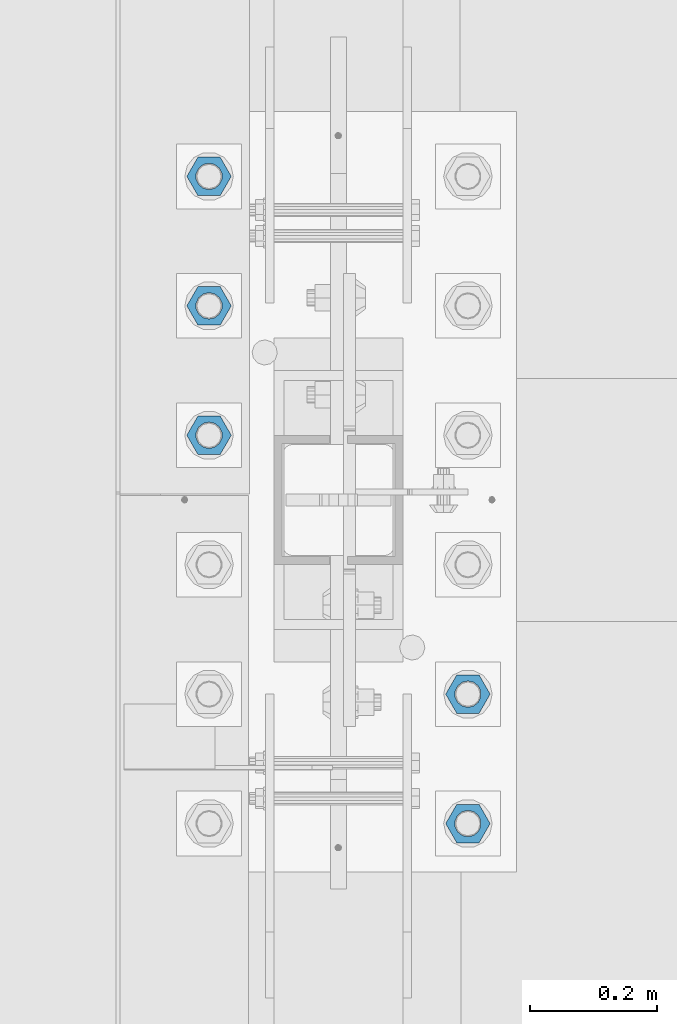
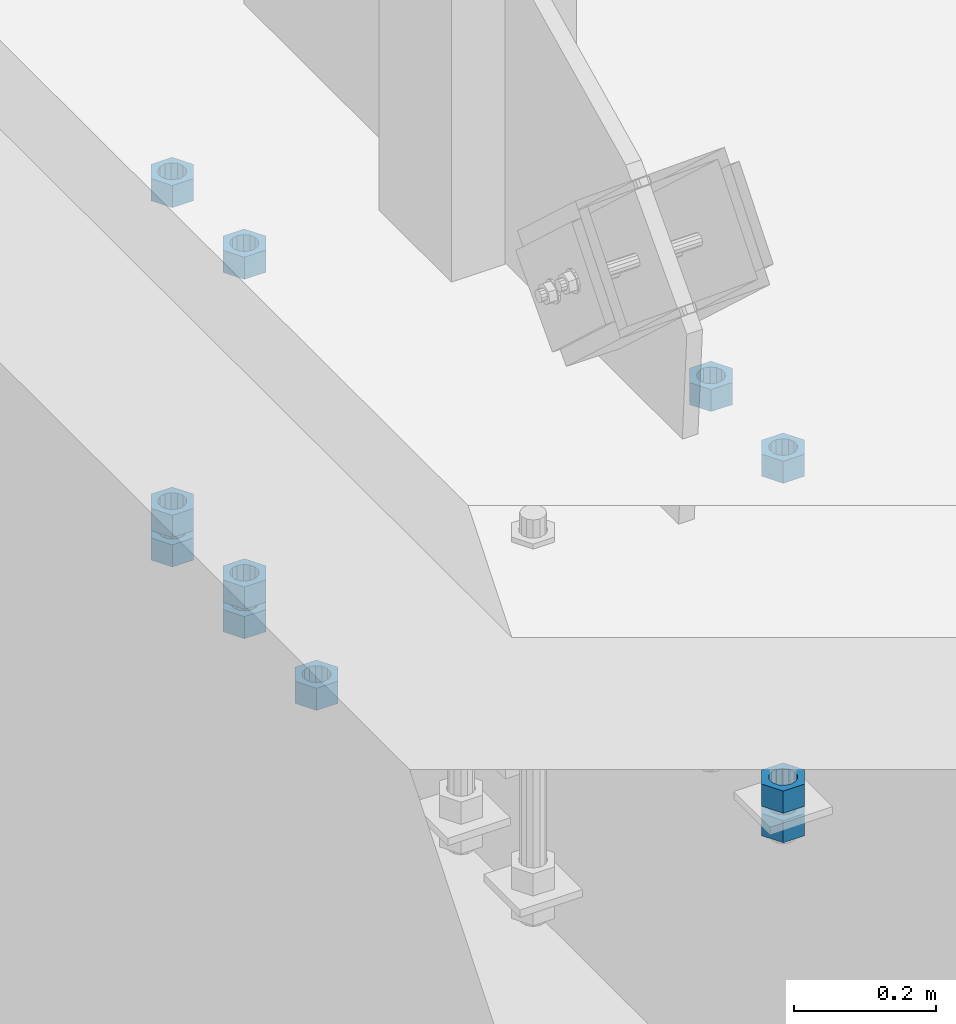
# One storey, part 985 of 1763: 11 columns, 1 element without a shape of its own.
"""IFC2X3 building model written with IfcOpenShell, lengths in millimetres."""

from ifc_helpers import new_model, si_unit, frame, origin_with_axes, place, context, subcontext, project, spatial, faceted_brep, material, type_object, element, aggregate, save


model = new_model("IFC2X3")

# Units and contexts
model_context = context("Model", 3, precision=1e-05, world=origin_with_axes())
body_context = subcontext(model_context, "Body", "Model", "MODEL_VIEW")
ifc_project = project(units=[si_unit("LENGTHUNIT", "METRE", prefix="MILLI"), si_unit("AREAUNIT", "SQUARE_METRE"), si_unit("VOLUMEUNIT", "CUBIC_METRE"), si_unit("MASSUNIT", "GRAM", prefix="KILO"), si_unit("TIMEUNIT", "SECOND"), si_unit("PLANEANGLEUNIT", "RADIAN"), si_unit("SOLIDANGLEUNIT", "STERADIAN"), si_unit("THERMODYNAMICTEMPERATUREUNIT", "DEGREE_CELSIUS"), si_unit("LUMINOUSINTENSITYUNIT", "LUMEN")], contexts=[model_context])

# Site, building, storey
site_placement = place(None, origin_with_axes())
site = spatial("IfcSite", under=ifc_project, at=site_placement, CompositionType="ELEMENT")
building_placement = place(site_placement, origin_with_axes())
building = spatial("IfcBuilding", under=site, at=building_placement, Name="Undefined", CompositionType="ELEMENT")
storey_placement = place(building_placement, origin_with_axes())
storey = spatial("IfcBuildingStorey", under=building, at=storey_placement, Name="Undefined", CompositionType="ELEMENT", Elevation=0.0)

# Assembly, columns
assembly_placement = place(storey_placement, origin_with_axes())
assembly = element("IfcElementAssembly", 1, at=assembly_placement, inside=storey, Name="TEMPLATE", AssemblyPlace="NOTDEFINED", PredefinedType="RIGID_FRAME")
ifc_material = material(Name="STEEL/A563")
column_type = type_object("IfcColumnType", Name="1-1/2_HEAVY_HEX_NUT", PredefinedType="NOTDEFINED")
column_1_placement = place(assembly_placement, frame((-87172.2372736984, -50.7999999999992, 5189.5375), z_axis=(0.0, 1.0, 0.0), x_axis=(0.0, 0.0, -1.0)))
column_1 = element("IfcColumn", 2, at=column_1_placement, type_object=column_type, material=ifc_material, Name="NUT", ObjectType="1-1/2_HEAVY_HEX_NUT", context=body_context, shape_type="Brep", body=[
    faceted_brep([(0.0, -34.9199981689453, 0.0), (0.0, -17.4599990844727, -30.25), (38.1000000000004, -17.4599990844727, -30.25), (38.1000000000004, -34.9199981689453, 0.0), (0.0, 17.4599990844727, -30.25), (38.1000000000004, 17.4599990844727, -30.25), (0.0, 34.9199981689453, 0.0), (38.1000000000004, 34.9199981689453, 0.0), (0.0, 17.4599990844727, 30.25), (38.1000000000004, 17.4599990844727, 30.25), (0.0, -17.4599990844727, 30.25), (38.1000000000004, -17.4599990844727, 30.25), (0.0, 0.0, 20.6399993896484), (0.0, 8.95536011056538, 18.5959968835978), (38.1000000000004, 8.95536011056538, 18.5959968835978), (38.1000000000004, 0.0, 20.6399993896484), (0.0, 16.1370013209453, 12.8688291298167), (38.1000000000004, 16.1370013209453, 12.8688291298167), (0.0, 20.1225115123816, 4.59283194104137), (38.1000000000004, 20.1225115123816, 4.59283194104137), (0.0, 20.1225115123816, -4.59283194104319), (38.1000000000004, 20.1225115123816, -4.59283194104319), (0.0, 16.1370013209453, -12.8688291298167), (38.1000000000004, 16.1370013209453, -12.8688291298167), (0.0, 8.95536011056538, -18.5959968835978), (38.1000000000004, 8.95536011056538, -18.5959968835978), (0.0, 0.0, -20.6399993896484), (38.1000000000004, 0.0, -20.6399993896484), (0.0, -8.95536011056538, -18.5959968835978), (38.1000000000004, -8.95536011056538, -18.5959968835978), (0.0, -16.1370013209453, -12.8688291298167), (38.1000000000004, -16.1370013209453, -12.8688291298167), (0.0, -20.1225115123816, -4.59283194104137), (38.1000000000004, -20.1225115123816, -4.59283194104137), (0.0, -20.1225115123816, 4.59283194104319), (38.1000000000004, -20.1225115123816, 4.59283194104319), (0.0, -16.1370013209453, 12.8688291298167), (38.1000000000004, -16.1370013209453, 12.8688291298167), (0.0, -8.95536011056538, 18.5959968835978), (38.1000000000004, -8.95536011056538, 18.5959968835978)], [[[0, 1, 2, 3]], [[1, 4, 5, 2]], [[4, 6, 7, 5]], [[6, 8, 9, 7]], [[8, 10, 11, 9]], [[10, 0, 3, 11]], [[12, 13, 14, 15]], [[13, 16, 17, 14]], [[16, 18, 19, 17]], [[18, 20, 21, 19]], [[20, 22, 23, 21]], [[22, 24, 25, 23]], [[24, 26, 27, 25]], [[26, 28, 29, 27]], [[28, 30, 31, 29]], [[30, 32, 33, 31]], [[32, 34, 35, 33]], [[34, 36, 37, 35]], [[36, 38, 39, 37]], [[38, 12, 15, 39]], [[5, 7, 9, 11, 3, 2], [17, 19, 21, 23, 25, 27, 29, 31, 33, 35, 37, 39, 15, 14]], [[10, 8, 6, 4, 1, 0], [38, 36, 34, 32, 30, 28, 26, 24, 22, 20, 18, 16, 13, 12]]]),
])
column_2_placement = place(assembly_placement, frame((-87172.2372736984, -50.7999999999992, 4622.8), z_axis=(0.0, 1.0, 0.0), x_axis=(0.0, 0.0, -1.0)))
column_2 = element("IfcColumn", 3, at=column_2_placement, type_object=column_type, material=ifc_material, Name="NUT", ObjectType="1-1/2_HEAVY_HEX_NUT", context=body_context, shape_type="Brep", body=[
    faceted_brep([(0.0, -34.9199981689453, 0.0), (0.0, -17.4599990844727, -30.25), (38.1000000000004, -17.4599990844727, -30.25), (38.1000000000004, -34.9199981689453, 0.0), (0.0, 17.4599990844727, -30.25), (38.1000000000004, 17.4599990844727, -30.25), (0.0, 34.9199981689453, 0.0), (38.1000000000004, 34.9199981689453, 0.0), (0.0, 17.4599990844727, 30.25), (38.1000000000004, 17.4599990844727, 30.25), (0.0, -17.4599990844727, 30.25), (38.1000000000004, -17.4599990844727, 30.25), (0.0, 0.0, 20.6399993896484), (0.0, 8.95536011056538, 18.5959968835978), (38.1000000000004, 8.95536011056538, 18.5959968835978), (38.1000000000004, 0.0, 20.6399993896484), (0.0, 16.1370013209453, 12.8688291298167), (38.1000000000004, 16.1370013209453, 12.8688291298167), (0.0, 20.1225115123816, 4.59283194104137), (38.1000000000004, 20.1225115123816, 4.59283194104137), (0.0, 20.1225115123816, -4.59283194104319), (38.1000000000004, 20.1225115123816, -4.59283194104319), (0.0, 16.1370013209453, -12.8688291298167), (38.1000000000004, 16.1370013209453, -12.8688291298167), (0.0, 8.95536011056538, -18.5959968835978), (38.1000000000004, 8.95536011056538, -18.5959968835978), (0.0, 0.0, -20.6399993896484), (38.1000000000004, 0.0, -20.6399993896484), (0.0, -8.95536011056538, -18.5959968835978), (38.1000000000004, -8.95536011056538, -18.5959968835978), (0.0, -16.1370013209453, -12.8688291298167), (38.1000000000004, -16.1370013209453, -12.8688291298167), (0.0, -20.1225115123816, -4.59283194104137), (38.1000000000004, -20.1225115123816, -4.59283194104137), (0.0, -20.1225115123816, 4.59283194104319), (38.1000000000004, -20.1225115123816, 4.59283194104319), (0.0, -16.1370013209453, 12.8688291298167), (38.1000000000004, -16.1370013209453, 12.8688291298167), (0.0, -8.95536011056538, 18.5959968835978), (38.1000000000004, -8.95536011056538, 18.5959968835978)], [[[0, 1, 2, 3]], [[1, 4, 5, 2]], [[4, 6, 7, 5]], [[6, 8, 9, 7]], [[8, 10, 11, 9]], [[10, 0, 3, 11]], [[12, 13, 14, 15]], [[13, 16, 17, 14]], [[16, 18, 19, 17]], [[18, 20, 21, 19]], [[20, 22, 23, 21]], [[22, 24, 25, 23]], [[24, 26, 27, 25]], [[26, 28, 29, 27]], [[28, 30, 31, 29]], [[30, 32, 33, 31]], [[32, 34, 35, 33]], [[34, 36, 37, 35]], [[36, 38, 39, 37]], [[38, 12, 15, 39]], [[5, 7, 9, 11, 3, 2], [17, 19, 21, 23, 25, 27, 29, 31, 33, 35, 37, 39, 15, 14]], [[10, 8, 6, 4, 1, 0], [38, 36, 34, 32, 30, 28, 26, 24, 22, 20, 18, 16, 13, 12]]]),
])
column_3_placement = place(assembly_placement, frame((-87172.2372736984, -50.7999999999992, 4572.0), z_axis=(0.0, 1.0, 0.0), x_axis=(0.0, 0.0, -1.0)))
column_3 = element("IfcColumn", 4, at=column_3_placement, type_object=column_type, material=ifc_material, Name="NUT", ObjectType="1-1/2_HEAVY_HEX_NUT", context=body_context, shape_type="Brep", body=[
    faceted_brep([(0.0, -34.9199981689453, 0.0), (0.0, -17.4599990844727, -30.25), (38.1000000000004, -17.4599990844727, -30.25), (38.1000000000004, -34.9199981689453, 0.0), (0.0, 17.4599990844727, -30.25), (38.1000000000004, 17.4599990844727, -30.25), (0.0, 34.9199981689453, 0.0), (38.1000000000004, 34.9199981689453, 0.0), (0.0, 17.4599990844727, 30.25), (38.1000000000004, 17.4599990844727, 30.25), (0.0, -17.4599990844727, 30.25), (38.1000000000004, -17.4599990844727, 30.25), (0.0, 0.0, 20.6399993896484), (0.0, 8.95536011056538, 18.5959968835978), (38.1000000000004, 8.95536011056538, 18.5959968835978), (38.1000000000004, 0.0, 20.6399993896484), (0.0, 16.1370013209453, 12.8688291298167), (38.1000000000004, 16.1370013209453, 12.8688291298167), (0.0, 20.1225115123816, 4.59283194104137), (38.1000000000004, 20.1225115123816, 4.59283194104137), (0.0, 20.1225115123816, -4.59283194104319), (38.1000000000004, 20.1225115123816, -4.59283194104319), (0.0, 16.1370013209453, -12.8688291298167), (38.1000000000004, 16.1370013209453, -12.8688291298167), (0.0, 8.95536011056538, -18.5959968835978), (38.1000000000004, 8.95536011056538, -18.5959968835978), (0.0, 0.0, -20.6399993896484), (38.1000000000004, 0.0, -20.6399993896484), (0.0, -8.95536011056538, -18.5959968835978), (38.1000000000004, -8.95536011056538, -18.5959968835978), (0.0, -16.1370013209453, -12.8688291298167), (38.1000000000004, -16.1370013209453, -12.8688291298167), (0.0, -20.1225115123816, -4.59283194104137), (38.1000000000004, -20.1225115123816, -4.59283194104137), (0.0, -20.1225115123816, 4.59283194104319), (38.1000000000004, -20.1225115123816, 4.59283194104319), (0.0, -16.1370013209453, 12.8688291298167), (38.1000000000004, -16.1370013209453, 12.8688291298167), (0.0, -8.95536011056538, 18.5959968835978), (38.1000000000004, -8.95536011056538, 18.5959968835978)], [[[0, 1, 2, 3]], [[1, 4, 5, 2]], [[4, 6, 7, 5]], [[6, 8, 9, 7]], [[8, 10, 11, 9]], [[10, 0, 3, 11]], [[12, 13, 14, 15]], [[13, 16, 17, 14]], [[16, 18, 19, 17]], [[18, 20, 21, 19]], [[20, 22, 23, 21]], [[22, 24, 25, 23]], [[24, 26, 27, 25]], [[26, 28, 29, 27]], [[28, 30, 31, 29]], [[30, 32, 33, 31]], [[32, 34, 35, 33]], [[34, 36, 37, 35]], [[36, 38, 39, 37]], [[38, 12, 15, 39]], [[5, 7, 9, 11, 3, 2], [17, 19, 21, 23, 25, 27, 29, 31, 33, 35, 37, 39, 15, 14]], [[10, 8, 6, 4, 1, 0], [38, 36, 34, 32, 30, 28, 26, 24, 22, 20, 18, 16, 13, 12]]]),
])
column_4_placement = place(assembly_placement, frame((-87172.2372736984, 152.400000000001, 5189.5375), z_axis=(0.0, 1.0, 0.0), x_axis=(0.0, 0.0, -1.0)))
column_4 = element("IfcColumn", 5, at=column_4_placement, type_object=column_type, material=ifc_material, Name="NUT", ObjectType="1-1/2_HEAVY_HEX_NUT", context=body_context, shape_type="Brep", body=[
    faceted_brep([(0.0, -34.9199981689453, 0.0), (0.0, -17.4599990844727, -30.25), (38.1000000000004, -17.4599990844727, -30.25), (38.1000000000004, -34.9199981689453, 0.0), (0.0, 17.4599990844727, -30.25), (38.1000000000004, 17.4599990844727, -30.25), (0.0, 34.9199981689453, 0.0), (38.1000000000004, 34.9199981689453, 0.0), (0.0, 17.4599990844727, 30.25), (38.1000000000004, 17.4599990844727, 30.25), (0.0, -17.4599990844727, 30.25), (38.1000000000004, -17.4599990844727, 30.25), (0.0, 0.0, 20.6399993896484), (0.0, 8.95536011056538, 18.5959968835978), (38.1000000000004, 8.95536011056538, 18.5959968835978), (38.1000000000004, 0.0, 20.6399993896484), (0.0, 16.1370013209453, 12.8688291298167), (38.1000000000004, 16.1370013209453, 12.8688291298167), (0.0, 20.1225115123816, 4.59283194104137), (38.1000000000004, 20.1225115123816, 4.59283194104137), (0.0, 20.1225115123816, -4.59283194104319), (38.1000000000004, 20.1225115123816, -4.59283194104319), (0.0, 16.1370013209453, -12.8688291298167), (38.1000000000004, 16.1370013209453, -12.8688291298167), (0.0, 8.95536011056538, -18.5959968835978), (38.1000000000004, 8.95536011056538, -18.5959968835978), (0.0, 0.0, -20.6399993896484), (38.1000000000004, 0.0, -20.6399993896484), (0.0, -8.95536011056538, -18.5959968835978), (38.1000000000004, -8.95536011056538, -18.5959968835978), (0.0, -16.1370013209453, -12.8688291298167), (38.1000000000004, -16.1370013209453, -12.8688291298167), (0.0, -20.1225115123816, -4.59283194104137), (38.1000000000004, -20.1225115123816, -4.59283194104137), (0.0, -20.1225115123816, 4.59283194104319), (38.1000000000004, -20.1225115123816, 4.59283194104319), (0.0, -16.1370013209453, 12.8688291298167), (38.1000000000004, -16.1370013209453, 12.8688291298167), (0.0, -8.95536011056538, 18.5959968835978), (38.1000000000004, -8.95536011056538, 18.5959968835978)], [[[0, 1, 2, 3]], [[1, 4, 5, 2]], [[4, 6, 7, 5]], [[6, 8, 9, 7]], [[8, 10, 11, 9]], [[10, 0, 3, 11]], [[12, 13, 14, 15]], [[13, 16, 17, 14]], [[16, 18, 19, 17]], [[18, 20, 21, 19]], [[20, 22, 23, 21]], [[22, 24, 25, 23]], [[24, 26, 27, 25]], [[26, 28, 29, 27]], [[28, 30, 31, 29]], [[30, 32, 33, 31]], [[32, 34, 35, 33]], [[34, 36, 37, 35]], [[36, 38, 39, 37]], [[38, 12, 15, 39]], [[5, 7, 9, 11, 3, 2], [17, 19, 21, 23, 25, 27, 29, 31, 33, 35, 37, 39, 15, 14]], [[10, 8, 6, 4, 1, 0], [38, 36, 34, 32, 30, 28, 26, 24, 22, 20, 18, 16, 13, 12]]]),
])
column_5_placement = place(assembly_placement, frame((-87578.6372736983, 558.800000000001, 4572.0), z_axis=(0.0, -1.0, 0.0), x_axis=(0.0, 0.0, -1.0)))
column_5 = element("IfcColumn", 6, at=column_5_placement, type_object=column_type, material=ifc_material, Name="NUT", ObjectType="1-1/2_HEAVY_HEX_NUT", context=body_context, shape_type="Brep", body=[
    faceted_brep([(0.0, -34.9199981689453, 0.0), (0.0, -17.4599990844727, -30.25), (38.1000000000004, -17.4599990844727, -30.25), (38.1000000000004, -34.9199981689453, 0.0), (0.0, 17.4599990844727, -30.25), (38.1000000000004, 17.4599990844727, -30.25), (0.0, 34.9199981689453, 0.0), (38.1000000000004, 34.9199981689453, 0.0), (0.0, 17.4599990844727, 30.25), (38.1000000000004, 17.4599990844727, 30.25), (0.0, -17.4599990844727, 30.25), (38.1000000000004, -17.4599990844727, 30.25), (0.0, 0.0, 20.6399993896484), (0.0, 8.95536011056538, 18.5959968835978), (38.1000000000004, 8.95536011056538, 18.5959968835978), (38.1000000000004, 0.0, 20.6399993896484), (0.0, 16.1370013209453, 12.8688291298167), (38.1000000000004, 16.1370013209453, 12.8688291298167), (0.0, 20.1225115123816, 4.59283194104137), (38.1000000000004, 20.1225115123816, 4.59283194104137), (0.0, 20.1225115123816, -4.59283194104319), (38.1000000000004, 20.1225115123816, -4.59283194104319), (0.0, 16.1370013209453, -12.8688291298167), (38.1000000000004, 16.1370013209453, -12.8688291298167), (0.0, 8.95536011056538, -18.5959968835978), (38.1000000000004, 8.95536011056538, -18.5959968835978), (0.0, 0.0, -20.6399993896484), (38.1000000000004, 0.0, -20.6399993896484), (0.0, -8.95536011056538, -18.5959968835978), (38.1000000000004, -8.95536011056538, -18.5959968835978), (0.0, -16.1370013209453, -12.8688291298167), (38.1000000000004, -16.1370013209453, -12.8688291298167), (0.0, -20.1225115123816, -4.59283194104137), (38.1000000000004, -20.1225115123816, -4.59283194104137), (0.0, -20.1225115123816, 4.59283194104319), (38.1000000000004, -20.1225115123816, 4.59283194104319), (0.0, -16.1370013209453, 12.8688291298167), (38.1000000000004, -16.1370013209453, 12.8688291298167), (0.0, -8.95536011056538, 18.5959968835978), (38.1000000000004, -8.95536011056538, 18.5959968835978)], [[[0, 1, 2, 3]], [[1, 4, 5, 2]], [[4, 6, 7, 5]], [[6, 8, 9, 7]], [[8, 10, 11, 9]], [[10, 0, 3, 11]], [[12, 13, 14, 15]], [[13, 16, 17, 14]], [[16, 18, 19, 17]], [[18, 20, 21, 19]], [[20, 22, 23, 21]], [[22, 24, 25, 23]], [[24, 26, 27, 25]], [[26, 28, 29, 27]], [[28, 30, 31, 29]], [[30, 32, 33, 31]], [[32, 34, 35, 33]], [[34, 36, 37, 35]], [[36, 38, 39, 37]], [[38, 12, 15, 39]], [[5, 7, 9, 11, 3, 2], [17, 19, 21, 23, 25, 27, 29, 31, 33, 35, 37, 39, 15, 14]], [[10, 8, 6, 4, 1, 0], [38, 36, 34, 32, 30, 28, 26, 24, 22, 20, 18, 16, 13, 12]]]),
])
column_6_placement = place(assembly_placement, frame((-87578.6372736983, 762.000000000001, 5189.5375), z_axis=(0.0, -1.0, 0.0), x_axis=(0.0, 0.0, -1.0)))
column_6 = element("IfcColumn", 7, at=column_6_placement, type_object=column_type, material=ifc_material, Name="NUT", ObjectType="1-1/2_HEAVY_HEX_NUT", context=body_context, shape_type="Brep", body=[
    faceted_brep([(0.0, -34.9199981689453, 0.0), (0.0, -17.4599990844727, -30.25), (38.1000000000004, -17.4599990844727, -30.25), (38.1000000000004, -34.9199981689453, 0.0), (0.0, 17.4599990844727, -30.25), (38.1000000000004, 17.4599990844727, -30.25), (0.0, 34.9199981689453, 0.0), (38.1000000000004, 34.9199981689453, 0.0), (0.0, 17.4599990844727, 30.25), (38.1000000000004, 17.4599990844727, 30.25), (0.0, -17.4599990844727, 30.25), (38.1000000000004, -17.4599990844727, 30.25), (0.0, 0.0, 20.6399993896484), (0.0, 8.95536011056538, 18.5959968835978), (38.1000000000004, 8.95536011056538, 18.5959968835978), (38.1000000000004, 0.0, 20.6399993896484), (0.0, 16.1370013209453, 12.8688291298167), (38.1000000000004, 16.1370013209453, 12.8688291298167), (0.0, 20.1225115123816, 4.59283194104137), (38.1000000000004, 20.1225115123816, 4.59283194104137), (0.0, 20.1225115123816, -4.59283194104319), (38.1000000000004, 20.1225115123816, -4.59283194104319), (0.0, 16.1370013209453, -12.8688291298167), (38.1000000000004, 16.1370013209453, -12.8688291298167), (0.0, 8.95536011056538, -18.5959968835978), (38.1000000000004, 8.95536011056538, -18.5959968835978), (0.0, 0.0, -20.6399993896484), (38.1000000000004, 0.0, -20.6399993896484), (0.0, -8.95536011056538, -18.5959968835978), (38.1000000000004, -8.95536011056538, -18.5959968835978), (0.0, -16.1370013209453, -12.8688291298167), (38.1000000000004, -16.1370013209453, -12.8688291298167), (0.0, -20.1225115123816, -4.59283194104137), (38.1000000000004, -20.1225115123816, -4.59283194104137), (0.0, -20.1225115123816, 4.59283194104319), (38.1000000000004, -20.1225115123816, 4.59283194104319), (0.0, -16.1370013209453, 12.8688291298167), (38.1000000000004, -16.1370013209453, 12.8688291298167), (0.0, -8.95536011056538, 18.5959968835978), (38.1000000000004, -8.95536011056538, 18.5959968835978)], [[[0, 1, 2, 3]], [[1, 4, 5, 2]], [[4, 6, 7, 5]], [[6, 8, 9, 7]], [[8, 10, 11, 9]], [[10, 0, 3, 11]], [[12, 13, 14, 15]], [[13, 16, 17, 14]], [[16, 18, 19, 17]], [[18, 20, 21, 19]], [[20, 22, 23, 21]], [[22, 24, 25, 23]], [[24, 26, 27, 25]], [[26, 28, 29, 27]], [[28, 30, 31, 29]], [[30, 32, 33, 31]], [[32, 34, 35, 33]], [[34, 36, 37, 35]], [[36, 38, 39, 37]], [[38, 12, 15, 39]], [[5, 7, 9, 11, 3, 2], [17, 19, 21, 23, 25, 27, 29, 31, 33, 35, 37, 39, 15, 14]], [[10, 8, 6, 4, 1, 0], [38, 36, 34, 32, 30, 28, 26, 24, 22, 20, 18, 16, 13, 12]]]),
])
column_7_placement = place(assembly_placement, frame((-87578.6372736983, 762.000000000001, 4622.8), z_axis=(0.0, -1.0, 0.0), x_axis=(0.0, 0.0, -1.0)))
column_7 = element("IfcColumn", 8, at=column_7_placement, type_object=column_type, material=ifc_material, Name="NUT", ObjectType="1-1/2_HEAVY_HEX_NUT", context=body_context, shape_type="Brep", body=[
    faceted_brep([(0.0, -34.9199981689453, 0.0), (0.0, -17.4599990844727, -30.25), (38.1000000000004, -17.4599990844727, -30.25), (38.1000000000004, -34.9199981689453, 0.0), (0.0, 17.4599990844727, -30.25), (38.1000000000004, 17.4599990844727, -30.25), (0.0, 34.9199981689453, 0.0), (38.1000000000004, 34.9199981689453, 0.0), (0.0, 17.4599990844727, 30.25), (38.1000000000004, 17.4599990844727, 30.25), (0.0, -17.4599990844727, 30.25), (38.1000000000004, -17.4599990844727, 30.25), (0.0, 0.0, 20.6399993896484), (0.0, 8.95536011056538, 18.5959968835978), (38.1000000000004, 8.95536011056538, 18.5959968835978), (38.1000000000004, 0.0, 20.6399993896484), (0.0, 16.1370013209453, 12.8688291298167), (38.1000000000004, 16.1370013209453, 12.8688291298167), (0.0, 20.1225115123816, 4.59283194104137), (38.1000000000004, 20.1225115123816, 4.59283194104137), (0.0, 20.1225115123816, -4.59283194104319), (38.1000000000004, 20.1225115123816, -4.59283194104319), (0.0, 16.1370013209453, -12.8688291298167), (38.1000000000004, 16.1370013209453, -12.8688291298167), (0.0, 8.95536011056538, -18.5959968835978), (38.1000000000004, 8.95536011056538, -18.5959968835978), (0.0, 0.0, -20.6399993896484), (38.1000000000004, 0.0, -20.6399993896484), (0.0, -8.95536011056538, -18.5959968835978), (38.1000000000004, -8.95536011056538, -18.5959968835978), (0.0, -16.1370013209453, -12.8688291298167), (38.1000000000004, -16.1370013209453, -12.8688291298167), (0.0, -20.1225115123816, -4.59283194104137), (38.1000000000004, -20.1225115123816, -4.59283194104137), (0.0, -20.1225115123816, 4.59283194104319), (38.1000000000004, -20.1225115123816, 4.59283194104319), (0.0, -16.1370013209453, 12.8688291298167), (38.1000000000004, -16.1370013209453, 12.8688291298167), (0.0, -8.95536011056538, 18.5959968835978), (38.1000000000004, -8.95536011056538, 18.5959968835978)], [[[0, 1, 2, 3]], [[1, 4, 5, 2]], [[4, 6, 7, 5]], [[6, 8, 9, 7]], [[8, 10, 11, 9]], [[10, 0, 3, 11]], [[12, 13, 14, 15]], [[13, 16, 17, 14]], [[16, 18, 19, 17]], [[18, 20, 21, 19]], [[20, 22, 23, 21]], [[22, 24, 25, 23]], [[24, 26, 27, 25]], [[26, 28, 29, 27]], [[28, 30, 31, 29]], [[30, 32, 33, 31]], [[32, 34, 35, 33]], [[34, 36, 37, 35]], [[36, 38, 39, 37]], [[38, 12, 15, 39]], [[5, 7, 9, 11, 3, 2], [17, 19, 21, 23, 25, 27, 29, 31, 33, 35, 37, 39, 15, 14]], [[10, 8, 6, 4, 1, 0], [38, 36, 34, 32, 30, 28, 26, 24, 22, 20, 18, 16, 13, 12]]]),
])
column_8_placement = place(assembly_placement, frame((-87578.6372736983, 762.000000000001, 4572.0), z_axis=(0.0, -1.0, 0.0), x_axis=(0.0, 0.0, -1.0)))
column_8 = element("IfcColumn", 9, at=column_8_placement, type_object=column_type, material=ifc_material, Name="NUT", ObjectType="1-1/2_HEAVY_HEX_NUT", context=body_context, shape_type="Brep", body=[
    faceted_brep([(0.0, -34.9199981689453, 0.0), (0.0, -17.4599990844727, -30.25), (38.1000000000004, -17.4599990844727, -30.25), (38.1000000000004, -34.9199981689453, 0.0), (0.0, 17.4599990844727, -30.25), (38.1000000000004, 17.4599990844727, -30.25), (0.0, 34.9199981689453, 0.0), (38.1000000000004, 34.9199981689453, 0.0), (0.0, 17.4599990844727, 30.25), (38.1000000000004, 17.4599990844727, 30.25), (0.0, -17.4599990844727, 30.25), (38.1000000000004, -17.4599990844727, 30.25), (0.0, 0.0, 20.6399993896484), (0.0, 8.95536011056538, 18.5959968835978), (38.1000000000004, 8.95536011056538, 18.5959968835978), (38.1000000000004, 0.0, 20.6399993896484), (0.0, 16.1370013209453, 12.8688291298167), (38.1000000000004, 16.1370013209453, 12.8688291298167), (0.0, 20.1225115123816, 4.59283194104137), (38.1000000000004, 20.1225115123816, 4.59283194104137), (0.0, 20.1225115123816, -4.59283194104319), (38.1000000000004, 20.1225115123816, -4.59283194104319), (0.0, 16.1370013209453, -12.8688291298167), (38.1000000000004, 16.1370013209453, -12.8688291298167), (0.0, 8.95536011056538, -18.5959968835978), (38.1000000000004, 8.95536011056538, -18.5959968835978), (0.0, 0.0, -20.6399993896484), (38.1000000000004, 0.0, -20.6399993896484), (0.0, -8.95536011056538, -18.5959968835978), (38.1000000000004, -8.95536011056538, -18.5959968835978), (0.0, -16.1370013209453, -12.8688291298167), (38.1000000000004, -16.1370013209453, -12.8688291298167), (0.0, -20.1225115123816, -4.59283194104137), (38.1000000000004, -20.1225115123816, -4.59283194104137), (0.0, -20.1225115123816, 4.59283194104319), (38.1000000000004, -20.1225115123816, 4.59283194104319), (0.0, -16.1370013209453, 12.8688291298167), (38.1000000000004, -16.1370013209453, 12.8688291298167), (0.0, -8.95536011056538, 18.5959968835978), (38.1000000000004, -8.95536011056538, 18.5959968835978)], [[[0, 1, 2, 3]], [[1, 4, 5, 2]], [[4, 6, 7, 5]], [[6, 8, 9, 7]], [[8, 10, 11, 9]], [[10, 0, 3, 11]], [[12, 13, 14, 15]], [[13, 16, 17, 14]], [[16, 18, 19, 17]], [[18, 20, 21, 19]], [[20, 22, 23, 21]], [[22, 24, 25, 23]], [[24, 26, 27, 25]], [[26, 28, 29, 27]], [[28, 30, 31, 29]], [[30, 32, 33, 31]], [[32, 34, 35, 33]], [[34, 36, 37, 35]], [[36, 38, 39, 37]], [[38, 12, 15, 39]], [[5, 7, 9, 11, 3, 2], [17, 19, 21, 23, 25, 27, 29, 31, 33, 35, 37, 39, 15, 14]], [[10, 8, 6, 4, 1, 0], [38, 36, 34, 32, 30, 28, 26, 24, 22, 20, 18, 16, 13, 12]]]),
])
column_9_placement = place(assembly_placement, frame((-87578.6372736983, 965.200000000001, 5189.5375), z_axis=(0.0, -1.0, 0.0), x_axis=(0.0, 0.0, -1.0)))
column_9 = element("IfcColumn", 10, at=column_9_placement, type_object=column_type, material=ifc_material, Name="NUT", ObjectType="1-1/2_HEAVY_HEX_NUT", context=body_context, shape_type="Brep", body=[
    faceted_brep([(0.0, -34.9199981689453, 0.0), (0.0, -17.4599990844727, -30.25), (38.1000000000004, -17.4599990844727, -30.25), (38.1000000000004, -34.9199981689453, 0.0), (0.0, 17.4599990844727, -30.25), (38.1000000000004, 17.4599990844727, -30.25), (0.0, 34.9199981689453, 0.0), (38.1000000000004, 34.9199981689453, 0.0), (0.0, 17.4599990844727, 30.25), (38.1000000000004, 17.4599990844727, 30.25), (0.0, -17.4599990844727, 30.25), (38.1000000000004, -17.4599990844727, 30.25), (0.0, 0.0, 20.6399993896484), (0.0, 8.95536011056538, 18.5959968835978), (38.1000000000004, 8.95536011056538, 18.5959968835978), (38.1000000000004, 0.0, 20.6399993896484), (0.0, 16.1370013209453, 12.8688291298167), (38.1000000000004, 16.1370013209453, 12.8688291298167), (0.0, 20.1225115123816, 4.59283194104137), (38.1000000000004, 20.1225115123816, 4.59283194104137), (0.0, 20.1225115123816, -4.59283194104319), (38.1000000000004, 20.1225115123816, -4.59283194104319), (0.0, 16.1370013209453, -12.8688291298167), (38.1000000000004, 16.1370013209453, -12.8688291298167), (0.0, 8.95536011056538, -18.5959968835978), (38.1000000000004, 8.95536011056538, -18.5959968835978), (0.0, 0.0, -20.6399993896484), (38.1000000000004, 0.0, -20.6399993896484), (0.0, -8.95536011056538, -18.5959968835978), (38.1000000000004, -8.95536011056538, -18.5959968835978), (0.0, -16.1370013209453, -12.8688291298167), (38.1000000000004, -16.1370013209453, -12.8688291298167), (0.0, -20.1225115123816, -4.59283194104137), (38.1000000000004, -20.1225115123816, -4.59283194104137), (0.0, -20.1225115123816, 4.59283194104319), (38.1000000000004, -20.1225115123816, 4.59283194104319), (0.0, -16.1370013209453, 12.8688291298167), (38.1000000000004, -16.1370013209453, 12.8688291298167), (0.0, -8.95536011056538, 18.5959968835978), (38.1000000000004, -8.95536011056538, 18.5959968835978)], [[[0, 1, 2, 3]], [[1, 4, 5, 2]], [[4, 6, 7, 5]], [[6, 8, 9, 7]], [[8, 10, 11, 9]], [[10, 0, 3, 11]], [[12, 13, 14, 15]], [[13, 16, 17, 14]], [[16, 18, 19, 17]], [[18, 20, 21, 19]], [[20, 22, 23, 21]], [[22, 24, 25, 23]], [[24, 26, 27, 25]], [[26, 28, 29, 27]], [[28, 30, 31, 29]], [[30, 32, 33, 31]], [[32, 34, 35, 33]], [[34, 36, 37, 35]], [[36, 38, 39, 37]], [[38, 12, 15, 39]], [[5, 7, 9, 11, 3, 2], [17, 19, 21, 23, 25, 27, 29, 31, 33, 35, 37, 39, 15, 14]], [[10, 8, 6, 4, 1, 0], [38, 36, 34, 32, 30, 28, 26, 24, 22, 20, 18, 16, 13, 12]]]),
])
column_10_placement = place(assembly_placement, frame((-87578.6372736983, 965.200000000001, 4622.8), z_axis=(0.0, -1.0, 0.0), x_axis=(0.0, 0.0, -1.0)))
column_10 = element("IfcColumn", 11, at=column_10_placement, type_object=column_type, material=ifc_material, Name="NUT", ObjectType="1-1/2_HEAVY_HEX_NUT", context=body_context, shape_type="Brep", body=[
    faceted_brep([(0.0, -34.9199981689453, 0.0), (0.0, -17.4599990844727, -30.25), (38.1000000000004, -17.4599990844727, -30.25), (38.1000000000004, -34.9199981689453, 0.0), (0.0, 17.4599990844727, -30.25), (38.1000000000004, 17.4599990844727, -30.25), (0.0, 34.9199981689453, 0.0), (38.1000000000004, 34.9199981689453, 0.0), (0.0, 17.4599990844727, 30.25), (38.1000000000004, 17.4599990844727, 30.25), (0.0, -17.4599990844727, 30.25), (38.1000000000004, -17.4599990844727, 30.25), (0.0, 0.0, 20.6399993896484), (0.0, 8.95536011056538, 18.5959968835978), (38.1000000000004, 8.95536011056538, 18.5959968835978), (38.1000000000004, 0.0, 20.6399993896484), (0.0, 16.1370013209453, 12.8688291298167), (38.1000000000004, 16.1370013209453, 12.8688291298167), (0.0, 20.1225115123816, 4.59283194104137), (38.1000000000004, 20.1225115123816, 4.59283194104137), (0.0, 20.1225115123816, -4.59283194104319), (38.1000000000004, 20.1225115123816, -4.59283194104319), (0.0, 16.1370013209453, -12.8688291298167), (38.1000000000004, 16.1370013209453, -12.8688291298167), (0.0, 8.95536011056538, -18.5959968835978), (38.1000000000004, 8.95536011056538, -18.5959968835978), (0.0, 0.0, -20.6399993896484), (38.1000000000004, 0.0, -20.6399993896484), (0.0, -8.95536011056538, -18.5959968835978), (38.1000000000004, -8.95536011056538, -18.5959968835978), (0.0, -16.1370013209453, -12.8688291298167), (38.1000000000004, -16.1370013209453, -12.8688291298167), (0.0, -20.1225115123816, -4.59283194104137), (38.1000000000004, -20.1225115123816, -4.59283194104137), (0.0, -20.1225115123816, 4.59283194104319), (38.1000000000004, -20.1225115123816, 4.59283194104319), (0.0, -16.1370013209453, 12.8688291298167), (38.1000000000004, -16.1370013209453, 12.8688291298167), (0.0, -8.95536011056538, 18.5959968835978), (38.1000000000004, -8.95536011056538, 18.5959968835978)], [[[0, 1, 2, 3]], [[1, 4, 5, 2]], [[4, 6, 7, 5]], [[6, 8, 9, 7]], [[8, 10, 11, 9]], [[10, 0, 3, 11]], [[12, 13, 14, 15]], [[13, 16, 17, 14]], [[16, 18, 19, 17]], [[18, 20, 21, 19]], [[20, 22, 23, 21]], [[22, 24, 25, 23]], [[24, 26, 27, 25]], [[26, 28, 29, 27]], [[28, 30, 31, 29]], [[30, 32, 33, 31]], [[32, 34, 35, 33]], [[34, 36, 37, 35]], [[36, 38, 39, 37]], [[38, 12, 15, 39]], [[5, 7, 9, 11, 3, 2], [17, 19, 21, 23, 25, 27, 29, 31, 33, 35, 37, 39, 15, 14]], [[10, 8, 6, 4, 1, 0], [38, 36, 34, 32, 30, 28, 26, 24, 22, 20, 18, 16, 13, 12]]]),
])
column_11_placement = place(assembly_placement, frame((-87578.6372736983, 965.200000000001, 4572.0), z_axis=(0.0, -1.0, 0.0), x_axis=(0.0, 0.0, -1.0)))
column_11 = element("IfcColumn", 12, at=column_11_placement, type_object=column_type, material=ifc_material, Name="NUT", ObjectType="1-1/2_HEAVY_HEX_NUT", context=body_context, shape_type="Brep", body=[
    faceted_brep([(0.0, -34.9199981689453, 0.0), (0.0, -17.4599990844727, -30.25), (38.1000000000004, -17.4599990844727, -30.25), (38.1000000000004, -34.9199981689453, 0.0), (0.0, 17.4599990844727, -30.25), (38.1000000000004, 17.4599990844727, -30.25), (0.0, 34.9199981689453, 0.0), (38.1000000000004, 34.9199981689453, 0.0), (0.0, 17.4599990844727, 30.25), (38.1000000000004, 17.4599990844727, 30.25), (0.0, -17.4599990844727, 30.25), (38.1000000000004, -17.4599990844727, 30.25), (0.0, 0.0, 20.6399993896484), (0.0, 8.95536011056538, 18.5959968835978), (38.1000000000004, 8.95536011056538, 18.5959968835978), (38.1000000000004, 0.0, 20.6399993896484), (0.0, 16.1370013209453, 12.8688291298167), (38.1000000000004, 16.1370013209453, 12.8688291298167), (0.0, 20.1225115123816, 4.59283194104137), (38.1000000000004, 20.1225115123816, 4.59283194104137), (0.0, 20.1225115123816, -4.59283194104319), (38.1000000000004, 20.1225115123816, -4.59283194104319), (0.0, 16.1370013209453, -12.8688291298167), (38.1000000000004, 16.1370013209453, -12.8688291298167), (0.0, 8.95536011056538, -18.5959968835978), (38.1000000000004, 8.95536011056538, -18.5959968835978), (0.0, 0.0, -20.6399993896484), (38.1000000000004, 0.0, -20.6399993896484), (0.0, -8.95536011056538, -18.5959968835978), (38.1000000000004, -8.95536011056538, -18.5959968835978), (0.0, -16.1370013209453, -12.8688291298167), (38.1000000000004, -16.1370013209453, -12.8688291298167), (0.0, -20.1225115123816, -4.59283194104137), (38.1000000000004, -20.1225115123816, -4.59283194104137), (0.0, -20.1225115123816, 4.59283194104319), (38.1000000000004, -20.1225115123816, 4.59283194104319), (0.0, -16.1370013209453, 12.8688291298167), (38.1000000000004, -16.1370013209453, 12.8688291298167), (0.0, -8.95536011056538, 18.5959968835978), (38.1000000000004, -8.95536011056538, 18.5959968835978)], [[[0, 1, 2, 3]], [[1, 4, 5, 2]], [[4, 6, 7, 5]], [[6, 8, 9, 7]], [[8, 10, 11, 9]], [[10, 0, 3, 11]], [[12, 13, 14, 15]], [[13, 16, 17, 14]], [[16, 18, 19, 17]], [[18, 20, 21, 19]], [[20, 22, 23, 21]], [[22, 24, 25, 23]], [[24, 26, 27, 25]], [[26, 28, 29, 27]], [[28, 30, 31, 29]], [[30, 32, 33, 31]], [[32, 34, 35, 33]], [[34, 36, 37, 35]], [[36, 38, 39, 37]], [[38, 12, 15, 39]], [[5, 7, 9, 11, 3, 2], [17, 19, 21, 23, 25, 27, 29, 31, 33, 35, 37, 39, 15, 14]], [[10, 8, 6, 4, 1, 0], [38, 36, 34, 32, 30, 28, 26, 24, 22, 20, 18, 16, 13, 12]]]),
])
aggregate(assembly, [column_1, column_2, column_3, column_4, column_5, column_6, column_7, column_8, column_9, column_10, column_11])

save(model, "model.ifc")
